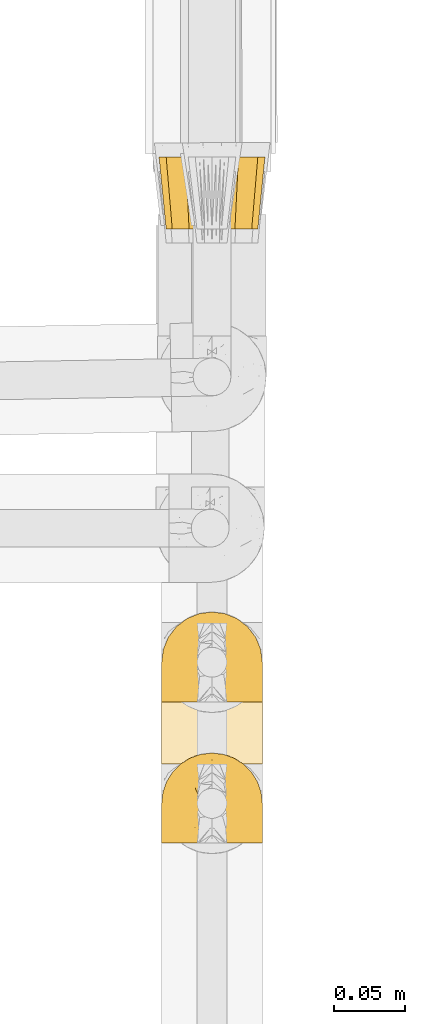
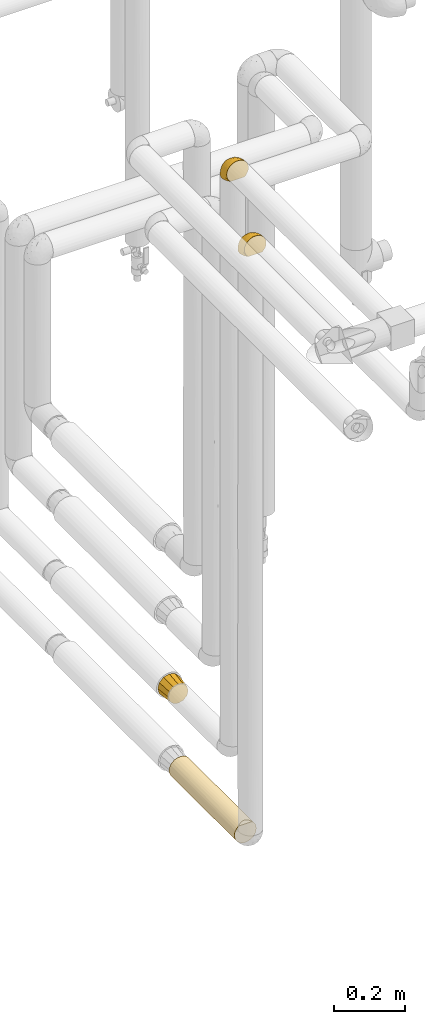
# One storey, part 74 of 827: 4 coverings.
"""IFC2X3 building model written with IfcOpenShell, lengths in millimetres."""

import ifcopenshell
import ifcopenshell.guid

model = None  # the IFC model being written
_history = None  # IfcOwnerHistory: only IFC2X3 demands one
_inside = {}  # id of a spatial element -> (the spatial element, [elements in it])
_under = {}  # id of a project, library or spatial element -> (it, [spatial elements below it])
_declared = {}  # id of a project -> (the project, [libraries it declares])
_typed = {}  # id of a type object -> (the type object, [elements of that type])
_made_of = {}  # id of a material, layer set ... -> (it, [elements and type objects made of it])


def new_model(schema):
    """Start an empty IFC model of exactly this schema.

    Asked for "IFC4X3", IfcOpenShell would pick the latest addendum, in which some entities
    have other attributes; the version numbers below select the first issue.
    IFC2X3 requires an IfcOwnerHistory on every rooted entity: one is made here for all.
    """
    global model, _history
    if schema == "IFC4X3":
        model = ifcopenshell.file(schema_version=(4, 3, 0, 0))
    else:
        model = ifcopenshell.file(schema=schema)
    _inside.clear()
    _under.clear()
    _declared.clear()
    _typed.clear()
    _made_of.clear()
    _history = None
    if model.schema == "IFC2X3":
        org = make("IfcOrganization", Name="unknown")
        user = make(
            "IfcPersonAndOrganization",
            ThePerson=make("IfcPerson", FamilyName="unknown"),
            TheOrganization=org,
        )
        app = make(
            "IfcApplication",
            ApplicationDeveloper=org,
            Version="unknown",
            ApplicationFullName="unknown",
            ApplicationIdentifier="unknown",
        )
        _history = make(
            "IfcOwnerHistory",
            OwningUser=user,
            OwningApplication=app,
            ChangeAction="ADDED",
            CreationDate=0,
        )
    return model


def make(cls, **values):
    """One entity of the class cls with the attributes given. An attribute that is None is left unset."""
    return model.create_entity(
        cls, **{name: value for name, value in values.items() if value is not None}
    )


def entity(cls, *values):
    """Any entity or typed value of the class cls, its attributes in the order of the schema. None: left unset."""
    e = model.create_entity(cls)
    for i, value in enumerate(values):
        if value is not None:
            e[i] = value
    return e


def rooted(cls, **values):
    """An entity with a GlobalId (a new one), such as an element, a storey or a relation."""
    return make(cls, GlobalId=ifcopenshell.guid.new(), OwnerHistory=_history, **values)


def si_unit(unit_type, name, prefix=None):
    """IfcSIUnit, for example si_unit("LENGTHUNIT", "METRE", prefix="MILLI")."""
    return make("IfcSIUnit", UnitType=unit_type, Prefix=prefix, Name=name)


def converted_unit(unit_type, name, factor, base, dimensions=None, offset=None):
    """IfcConversionBasedUnit, such as the inch: factor (a typed value) times the base unit."""
    return make(
        "IfcConversionBasedUnit"
        if offset is None
        else "IfcConversionBasedUnitWithOffset",
        ConversionOffset=offset,
        Dimensions=None
        if dimensions is None
        else entity("IfcDimensionalExponents", *dimensions),
        UnitType=unit_type,
        Name=name,
        ConversionFactor=make(
            "IfcMeasureWithUnit", ValueComponent=factor, UnitComponent=base
        ),
    )


def derived_unit(unit_type, elements):
    """IfcDerivedUnit: a product of units, each with its exponent."""
    return make(
        "IfcDerivedUnit",
        Elements=[
            make("IfcDerivedUnitElement", Unit=unit, Exponent=power)
            for unit, power in elements
        ],
        UnitType=unit_type,
    )


def assignment(units):
    """IfcUnitAssignment: the units of a project."""
    return None if units is None else make("IfcUnitAssignment", Units=units)


def point(xyz):
    """IfcCartesianPoint."""
    return None if xyz is None else make("IfcCartesianPoint", Coordinates=xyz)


def direction(xyz):
    """IfcDirection."""
    return None if xyz is None else make("IfcDirection", DirectionRatios=xyz)


def frame(location, z_axis=None, x_axis=None):
    """IfcAxis2Placement3D, a coordinate frame: its origin and axes. An axis left out is left unset."""
    return make(
        "IfcAxis2Placement3D",
        Location=point(location),
        Axis=direction(z_axis),
        RefDirection=direction(x_axis),
    )


def origin():
    """The frame at (0, 0, 0) with its axes left unset."""
    return frame((0.0, 0.0, 0.0))


def place(relative_to, where):
    """IfcLocalPlacement: puts the frame where relative to a parent placement (None: the world)."""
    return make(
        "IfcLocalPlacement", PlacementRelTo=relative_to, RelativePlacement=where
    )


def context(
    kind, dimensions, precision=None, world=None, true_north=None, identifier=None
):
    """IfcGeometricRepresentationContext, for example the 3D "Model" context."""
    return make(
        "IfcGeometricRepresentationContext",
        ContextIdentifier=identifier,
        ContextType=kind,
        CoordinateSpaceDimension=dimensions,
        Precision=precision,
        WorldCoordinateSystem=world,
        TrueNorth=true_north,
    )


def subcontext(parent, identifier, kind, view, scale=None):
    """IfcGeometricRepresentationSubContext, for example "Body" below "Model"."""
    return make(
        "IfcGeometricRepresentationSubContext",
        ContextIdentifier=identifier,
        ContextType=kind,
        ParentContext=parent,
        TargetScale=scale,
        TargetView=view,
    )


def project(units=None, contexts=None):
    """IfcProject with its units and contexts."""
    return rooted(
        "IfcProject",
        Name="project",
        RepresentationContexts=contexts,
        UnitsInContext=assignment(units),
    )


def spatial(cls, under=None, at=None, **own):
    """A site, building, storey or space (cls), placed at a placement, below another one or the project."""
    s = rooted(cls, ObjectPlacement=at, **own)
    if under is not None:
        _under.setdefault(under.id(), (under, []))[1].append(s)
    return s


def faces_of(points, faces, orient=None, outer=None):
    """IfcFace entities. A face is a list of loops; a loop is a list of indices into points, from 0.

    orient and outer hold one flag for each loop. By default every Orientation is true, the
    first loop of a face is its IfcFaceOuterBound and the others are IfcFaceBound.
    """
    made = []
    for i, loops in enumerate(faces):
        bounds = []
        for j, loop in enumerate(loops):
            is_outer = j == 0 if outer is None else outer[i][j]
            bounds.append(
                make(
                    "IfcFaceOuterBound" if is_outer else "IfcFaceBound",
                    Bound=make("IfcPolyLoop", Polygon=[points[k] for k in loop]),
                    Orientation=True if orient is None else orient[i][j],
                )
            )
        made.append(make("IfcFace", Bounds=bounds))
    return made


def faceted_brep(points, faces, orient=None, outer=None, voids=None):
    """IfcFacetedBrep: a solid bounded by flat faces; with voids (closed shells), ...WithVoids."""
    shared = [point(p) for p in points]
    hull = make("IfcClosedShell", CfsFaces=faces_of(shared, faces, orient, outer))
    if voids is None:
        return make("IfcFacetedBrep", Outer=hull)
    return make(
        "IfcFacetedBrepWithVoids",
        Outer=hull,
        Voids=[
            make(cls, CfsFaces=faces_of(shared, fs, o, b)) for cls, fs, o, b in voids
        ],
    )


def shape(context_of_items, identifier, shape_type, items):
    """IfcShapeRepresentation: the items that make up one representation, for example the "Body"."""
    return make(
        "IfcShapeRepresentation",
        ContextOfItems=context_of_items,
        RepresentationIdentifier=identifier,
        RepresentationType=shape_type,
        Items=items,
    )


def made_of(thing, what):
    """Note that an element or type object is made of a material, layer set ...; save() writes the relation."""
    if what is not None:
        _made_of.setdefault(what.id(), (what, []))[1].append(thing)
    return thing


def element(
    cls,
    number,
    at=None,
    inside=None,
    cuts=None,
    type_object=None,
    material=None,
    context=None,
    identifier="Body",
    shape_type=None,
    held_by="IfcProductDefinitionShape",
    body=None,
    shapes=None,
    **own,
):
    """One element of the class cls, such as IfcWall. Its Tag is "e" and its number.

    at: its placement. inside: the storey or other place that contains it. cuts: it is an
    opening in that element (IfcRelVoidsElement). A single representation is given by context,
    identifier, shape_type and body (its items); several are given by shapes. held_by: the class
    of the entity that holds the representations. save() writes the other relations.
    """
    e = rooted(cls, Tag="e%d" % number, ObjectPlacement=at, **own)
    if body is not None:
        shapes = [shape(context, identifier, shape_type, body)]
    if shapes is not None:
        e.Representation = make(held_by, Representations=shapes)
    if inside is not None:
        _inside.setdefault(inside.id(), (inside, []))[1].append(e)
    if cuts is not None:
        rooted(
            "IfcRelVoidsElement", RelatingBuildingElement=cuts, RelatedOpeningElement=e
        )
    if type_object is not None:
        _typed.setdefault(type_object.id(), (type_object, []))[1].append(e)
    return made_of(e, material)


def aggregate(whole, parts):
    """IfcRelAggregates: a whole, such as a stair, and the parts it consists of."""
    return rooted("IfcRelAggregates", RelatingObject=whole, RelatedObjects=parts)


def save(model, path):
    """Write the relations noted so far, then the file.

    IfcRelAggregates (storeys below a building ...), IfcRelContainedInSpatialStructure (elements
    in a storey), IfcRelDefinesByType, IfcRelAssociatesMaterial and IfcRelDeclares: one each for
    every whole, place, type object, material and project.
    """
    for whole, parts in _under.values():
        aggregate(whole, parts)
    for where, things in _inside.values():
        rooted(
            "IfcRelContainedInSpatialStructure",
            RelatedElements=things,
            RelatingStructure=where,
        )
    for kind, things in _typed.values():
        rooted("IfcRelDefinesByType", RelatedObjects=things, RelatingType=kind)
    for what, things in _made_of.values():
        rooted("IfcRelAssociatesMaterial", RelatedObjects=things, RelatingMaterial=what)
    for by, libraries in _declared.values():
        rooted("IfcRelDeclares", RelatingContext=by, RelatedDefinitions=libraries)
    model.write(path)


model = new_model("IFC2X3")

# Units and contexts
model_context = context("Model", 3, precision=0.01, world=origin(), true_north=direction((6.12303176911189e-17, 1.0)))
body_context = subcontext(model_context, "Body", "Model", "MODEL_VIEW")
ifc_project = project(units=[si_unit("LENGTHUNIT", "METRE", prefix="MILLI"), si_unit("AREAUNIT", "SQUARE_METRE"), si_unit("VOLUMEUNIT", "CUBIC_METRE"), converted_unit("PLANEANGLEUNIT", "DEGREE", entity("IfcRatioMeasure", 0.0174532925199433), si_unit("PLANEANGLEUNIT", "RADIAN"), dimensions=[0, 0, 0, 0, 0, 0, 0]), si_unit("MASSUNIT", "GRAM", prefix="KILO"), derived_unit("MASSDENSITYUNIT", [(si_unit("MASSUNIT", "GRAM", prefix="KILO"), 1), (si_unit("LENGTHUNIT", "METRE"), -3)]), derived_unit("MOMENTOFINERTIAUNIT", [(si_unit("LENGTHUNIT", "METRE"), 4)]), si_unit("TIMEUNIT", "SECOND"), si_unit("FREQUENCYUNIT", "HERTZ"), si_unit("THERMODYNAMICTEMPERATUREUNIT", "DEGREE_CELSIUS"), derived_unit("THERMALTRANSMITTANCEUNIT", [(si_unit("MASSUNIT", "GRAM", prefix="KILO"), 1), (si_unit("THERMODYNAMICTEMPERATUREUNIT", "KELVIN"), -1), (si_unit("TIMEUNIT", "SECOND"), -3)]), derived_unit("VOLUMETRICFLOWRATEUNIT", [(si_unit("LENGTHUNIT", "METRE"), 3), (si_unit("TIMEUNIT", "SECOND"), -1)]), derived_unit("MASSFLOWRATEUNIT", [(si_unit("MASSUNIT", "GRAM", prefix="KILO"), 1), (si_unit("TIMEUNIT", "SECOND"), -1)]), derived_unit("ROTATIONALFREQUENCYUNIT", [(si_unit("TIMEUNIT", "SECOND"), -1)]), si_unit("ELECTRICCURRENTUNIT", "AMPERE"), si_unit("ELECTRICVOLTAGEUNIT", "VOLT"), si_unit("POWERUNIT", "WATT"), si_unit("FORCEUNIT", "NEWTON", prefix="KILO"), si_unit("ILLUMINANCEUNIT", "LUX"), si_unit("LUMINOUSFLUXUNIT", "LUMEN"), si_unit("LUMINOUSINTENSITYUNIT", "CANDELA"), derived_unit("USERDEFINED", [(si_unit("MASSUNIT", "GRAM", prefix="KILO"), -1), (si_unit("LENGTHUNIT", "METRE"), -2), (si_unit("TIMEUNIT", "SECOND"), 3), (si_unit("LUMINOUSFLUXUNIT", "LUMEN"), 1)]), derived_unit("LINEARVELOCITYUNIT", [(si_unit("LENGTHUNIT", "METRE"), 1), (si_unit("TIMEUNIT", "SECOND"), -1)]), si_unit("PRESSUREUNIT", "PASCAL"), derived_unit("USERDEFINED", [(si_unit("LENGTHUNIT", "METRE"), -2), (si_unit("MASSUNIT", "GRAM", prefix="KILO"), 1), (si_unit("TIMEUNIT", "SECOND"), -2)]), derived_unit("LINEARFORCEUNIT", [(si_unit("MASSUNIT", "GRAM", prefix="KILO"), 1), (si_unit("LENGTHUNIT", "METRE"), 1), (si_unit("TIMEUNIT", "SECOND"), -2), (si_unit("LENGTHUNIT", "METRE"), -1)]), derived_unit("PLANARFORCEUNIT", [(si_unit("MASSUNIT", "GRAM", prefix="KILO"), 1), (si_unit("LENGTHUNIT", "METRE"), 1), (si_unit("TIMEUNIT", "SECOND"), -2), (si_unit("LENGTHUNIT", "METRE"), -2)])], contexts=[model_context])

# Site, building, storey
site_placement = place(None, origin())
site = spatial("IfcSite", under=ifc_project, at=site_placement, CompositionType="ELEMENT")
building_placement = place(site_placement, origin())
building = spatial("IfcBuilding", under=site, at=building_placement, CompositionType="ELEMENT")
storey_placement = place(building_placement, frame((0.0, 0.0, 28200.0)))
storey = spatial("IfcBuildingStorey", under=building, at=storey_placement, Name="08", CompositionType="ELEMENT", Elevation=28200.0)

# Coverings
covering_1_placement = place(storey_placement, frame((17891.28, 10631.6, 2820.54)))
element("IfcCovering", 1, at=covering_1_placement, inside=storey, Name=":ADSK_", ObjectType=":ADSK_", PredefinedType="INSULATION", context=body_context, shape_type="Brep", body=[
    faceted_brep([(69.36, 1.6, 45.07), (65.11, 1.6, 51.83), (59.47, 1.6, 57.47), (52.71, 1.6, 61.72), (45.17, 1.6, 64.35), (37.25, 1.6, 65.25), (29.31, 1.6, 64.35), (21.77, 1.6, 61.71), (15.01, 1.6, 57.46), (9.37, 1.6, 51.82), (5.12, 1.6, 45.06), (2.49, 1.6, 37.52), (1.6, 1.6, 29.6), (2.48, 1.6, 21.69), (5.1, 1.6, 14.19), (9.31, 1.6, 7.45), (14.9, 1.6, 1.82), (16.96, 1.6, 1.82), (18.43, 1.6, 1.82), (20.19, 1.6, 1.82), (21.96, 1.6, 1.82), (23.72, 1.6, 1.82), (25.49, 1.6, 1.82), (27.25, 1.6, 1.82), (29.02, 1.6, 1.82), (30.78, 1.6, 1.82), (32.55, 1.6, 1.82), (34.31, 1.6, 1.82), (36.08, 1.6, 1.82), (37.84, 1.6, 1.82), (39.61, 1.6, 1.82), (41.37, 1.6, 1.82), (43.14, 1.6, 1.82), (45.19, 1.6, 1.82), (47.25, 1.6, 1.82), (49.31, 1.6, 1.82), (51.36, 1.6, 1.82), (53.42, 1.6, 1.82), (55.48, 1.6, 1.82), (57.53, 1.6, 1.82), (59.59, 1.6, 1.82), (65.19, 1.6, 7.46), (69.4, 1.6, 14.2), (72.01, 1.6, 21.71), (72.9, 1.6, 29.6), (72.0, 1.6, 37.53), (14.9, 1.82, 1.6), (9.3, 7.46, 1.6), (5.09, 14.2, 1.6), (2.48, 21.7, 1.6), (1.6, 29.6, 1.6), (2.81, 38.83, 1.6), (6.37, 47.43, 1.6), (12.04, 54.81, 1.6), (19.42, 60.47, 1.6), (28.02, 64.04, 1.6), (37.25, 65.25, 1.6), (46.47, 64.04, 1.6), (55.07, 60.47, 1.6), (62.45, 54.81, 1.6), (68.12, 47.43, 1.6), (71.68, 38.83, 1.6), (72.9, 29.6, 1.6), (72.01, 21.7, 1.6), (69.4, 14.2, 1.6), (65.19, 7.46, 1.6), (59.59, 1.82, 1.6), (58.56, 1.82, 1.6), (56.8, 1.82, 1.6), (55.4, 1.82, 1.6), (54.0, 1.82, 1.6), (52.61, 1.82, 1.6), (51.21, 1.82, 1.6), (49.81, 1.82, 1.6), (48.42, 1.82, 1.6), (47.02, 1.82, 1.6), (45.62, 1.82, 1.6), (44.23, 1.82, 1.6), (42.83, 1.82, 1.6), (41.43, 1.82, 1.6), (40.04, 1.82, 1.6), (38.64, 1.82, 1.6), (37.25, 1.82, 1.6), (35.48, 1.82, 1.6), (33.72, 1.82, 1.6), (31.95, 1.82, 1.6), (30.19, 1.82, 1.6), (28.42, 1.82, 1.6), (26.66, 1.82, 1.6), (24.89, 1.82, 1.6), (23.13, 1.82, 1.6), (21.07, 1.82, 1.6), (19.01, 1.82, 1.6), (16.96, 1.82, 1.6), (50.36, 1.75, 1.76), (51.91, 1.76, 1.75), (27.73, 1.76, 1.75), (29.06, 1.77, 1.74), (23.01, 1.75, 1.76), (39.29, 1.76, 1.75), (16.3, 1.76, 1.75), (17.69, 1.76, 1.75), (42.09, 1.76, 1.75), (43.53, 1.76, 1.75), (58.23, 1.75, 1.76), (59.59, 1.76, 1.75), (46.32, 1.75, 1.76), (47.68, 1.76, 1.75), (19.0, 1.75, 1.76), (30.39, 1.76, 1.75), (31.67, 1.74, 1.77), (37.94, 1.77, 1.74), (36.57, 1.76, 1.75), (45.01, 1.76, 1.75), (35.19, 1.74, 1.77), (26.37, 1.74, 1.77), (25.1, 1.76, 1.75), (56.91, 1.75, 1.76), (40.68, 1.76, 1.75), (32.77, 1.79, 1.71), (20.34, 1.77, 1.74), (21.67, 1.76, 1.75), (33.92, 1.76, 1.75), (53.39, 1.77, 1.74), (54.7, 1.76, 1.75), (14.9, 1.76, 1.75), (49.03, 1.76, 1.75), (3.58, 13.11, 13.1), (6.24, 8.19, 9.65), (1.6, 25.85, 15.6), (1.6, 27.73, 8.6), (1.6, 15.6, 25.84), (9.92, 5.21, 5.2), (1.6, 20.72, 20.72), (1.6, 7.07, 28.13), (27.59, 35.56, 53.85), (25.47, 16.98, 61.29), (37.25, 25.95, 60.4), (2.39, 35.65, 11.52), (4.31, 42.61, 8.83), (4.31, 40.07, 17.53), (7.06, 20.45, 44.61), (7.06, 10.53, 47.7), (12.03, 14.87, 53.12), (18.65, 42.8, 43.01), (15.3, 33.34, 47.84), (21.13, 34.61, 51.46), (30.63, 61.84, 20.14), (23.6, 60.44, 17.45), (37.25, 14.29, 62.72), (15.54, 57.01, 11.49), (8.96, 49.61, 14.46), (2.3, 24.93, 27.74), (2.37, 32.74, 18.37), (3.14, 21.53, 34.41), (3.59, 11.52, 40.11), (18.27, 12.66, 58.72), (7.07, 34.11, 35.51), (8.53, 43.52, 27.21), (3.86, 32.29, 28.03), (13.04, 24.41, 50.73), (18.27, 24.95, 54.89), (26.27, 44.19, 46.54), (23.06, 56.25, 28.04), (29.25, 56.83, 31.36), (15.54, 53.51, 23.34), (24.41, 50.94, 37.9), (31.04, 50.38, 41.63), (37.25, 46.61, 46.6), (37.25, 36.28, 53.5), (37.25, 62.73, 14.29), (15.08, 47.4, 33.68), (12.03, 38.92, 39.51), (9.82, 29.55, 43.99), (6.14, 26.82, 39.36), (37.25, 60.41, 25.95), (37.25, 53.51, 36.28), (70.63, 32.3, 28.03), (67.42, 34.1, 35.52), (68.34, 26.82, 39.39), (43.86, 61.84, 20.14), (51.43, 56.24, 28.04), (50.89, 60.44, 17.45), (58.95, 53.51, 23.35), (58.95, 57.01, 11.5), (65.53, 49.61, 14.46), (43.44, 50.38, 41.63), (48.21, 44.18, 46.55), (50.07, 50.94, 37.92), (67.43, 20.45, 44.62), (67.43, 10.52, 47.71), (70.89, 11.52, 40.12), (55.83, 42.79, 43.03), (59.41, 47.39, 33.7), (72.9, 27.73, 8.6), (72.11, 35.65, 11.52), (72.12, 32.74, 18.37), (72.9, 7.07, 28.13), (70.18, 40.07, 17.53), (70.18, 42.61, 8.83), (46.9, 35.54, 53.86), (49.01, 16.98, 61.3), (56.21, 24.95, 54.9), (56.21, 12.65, 58.72), (62.45, 14.87, 53.13), (72.9, 25.85, 15.6), (62.45, 38.91, 39.53), (59.18, 33.34, 47.86), (64.66, 29.54, 44.01), (71.35, 21.54, 34.41), (72.9, 15.6, 25.84), (65.96, 43.51, 27.23), (61.44, 24.4, 50.74), (45.24, 56.83, 31.37), (72.19, 24.93, 27.74), (72.9, 20.72, 20.72), (53.31, 35.61, 50.81), (70.91, 13.11, 13.1), (68.25, 9.66, 8.18), (64.57, 5.21, 5.2)], [[[0, 1, 2, 3, 4, 5, 6, 7, 8, 9, 10, 11, 12, 13, 14, 15, 16, 17, 18, 19, 20, 21, 22, 23, 24, 25, 26, 27, 28, 29, 30, 31, 32, 33, 34, 35, 36, 37, 38, 39, 40, 41, 42, 43, 44, 45]], [[46, 47, 48, 49, 50, 51, 52, 53, 54, 55, 56, 57, 58, 59, 60, 61, 62, 63, 64, 65, 66, 67, 68, 69, 70, 71, 72, 73, 74, 75, 76, 77, 78, 79, 80, 81, 82, 83, 84, 85, 86, 87, 88, 89, 90, 91, 92, 93]], [[94, 72, 95]], [[96, 87, 97]], [[20, 98, 21]], [[99, 81, 80]], [[100, 93, 101]], [[102, 103, 32]], [[104, 105, 40]], [[67, 105, 104]], [[106, 107, 34]], [[18, 101, 108]], [[109, 85, 110]], [[36, 94, 95]], [[81, 111, 82]], [[29, 28, 112]], [[17, 101, 18]], [[103, 113, 33]], [[24, 96, 97]], [[28, 114, 112]], [[115, 22, 116]], [[31, 102, 32]], [[68, 104, 117]], [[31, 118, 102]], [[84, 119, 85]], [[120, 91, 121]], [[23, 22, 115]], [[114, 27, 122]], [[123, 37, 95]], [[117, 124, 69]], [[67, 66, 105]], [[104, 39, 117]], [[123, 124, 37]], [[100, 17, 16]], [[100, 125, 46]], [[17, 100, 101]], [[107, 126, 35]], [[92, 108, 101]], [[115, 88, 96]], [[114, 122, 83]], [[101, 93, 92]], [[93, 100, 46]], [[16, 125, 100]], [[108, 19, 18]], [[120, 121, 19]], [[108, 92, 120]], [[19, 108, 120]], [[67, 104, 68]], [[39, 104, 40]], [[69, 68, 117]], [[117, 39, 38]], [[70, 124, 123]], [[124, 70, 69]], [[38, 124, 117]], [[124, 38, 37]], [[72, 71, 95]], [[71, 123, 95]], [[71, 70, 123]], [[126, 94, 35]], [[37, 36, 95]], [[75, 74, 107]], [[73, 72, 94]], [[94, 36, 35]], [[94, 126, 73]], [[74, 73, 126]], [[106, 76, 75]], [[76, 106, 113]], [[113, 106, 33]], [[107, 35, 34]], [[106, 34, 33]], [[126, 107, 74]], [[107, 106, 75]], [[78, 77, 103]], [[77, 113, 103]], [[77, 76, 113]], [[102, 78, 103]], [[33, 32, 103]], [[80, 79, 118]], [[102, 118, 79]], [[112, 111, 29]], [[118, 31, 30]], [[79, 78, 102]], [[99, 111, 81]], [[112, 82, 111]], [[111, 99, 29]], [[30, 29, 99]], [[112, 83, 82]], [[27, 114, 28]], [[99, 118, 30]], [[118, 99, 80]], [[114, 83, 112]], [[84, 83, 122]], [[109, 110, 25]], [[122, 27, 26]], [[119, 110, 85]], [[20, 19, 121]], [[25, 110, 26]], [[91, 120, 92]], [[90, 98, 121]], [[121, 91, 90]], [[23, 115, 96]], [[88, 115, 116]], [[116, 98, 89]], [[89, 88, 116]], [[23, 96, 24]], [[87, 96, 88]], [[25, 24, 109]], [[97, 87, 86]], [[90, 89, 98]], [[116, 22, 21]], [[122, 26, 119]], [[86, 85, 109]], [[109, 97, 86]], [[97, 109, 24]], [[110, 119, 26]], [[122, 119, 84]], [[121, 98, 20]], [[21, 98, 116]], [[48, 127, 49]], [[48, 47, 128]], [[49, 129, 130, 50]], [[129, 49, 127]], [[131, 127, 13]], [[46, 125, 132]], [[16, 15, 132]], [[127, 128, 14]], [[127, 131, 133, 129]], [[14, 13, 127]], [[13, 12, 134, 131]], [[46, 132, 47]], [[48, 128, 127]], [[47, 132, 128]], [[15, 128, 132]], [[125, 16, 132]], [[15, 14, 128]], [[135, 136, 137]], [[50, 130, 138]], [[139, 52, 51]], [[138, 140, 139]], [[141, 142, 143]], [[144, 145, 146]], [[134, 12, 11]], [[136, 135, 146]], [[147, 55, 148]], [[136, 6, 149]], [[150, 54, 53]], [[151, 53, 52]], [[54, 148, 55]], [[54, 150, 148]], [[151, 52, 139]], [[133, 152, 153]], [[154, 131, 155]], [[134, 11, 155]], [[8, 7, 156]], [[143, 9, 8]], [[155, 131, 134]], [[155, 11, 10]], [[142, 155, 10]], [[157, 158, 159]], [[155, 141, 154]], [[160, 161, 145]], [[160, 143, 161]], [[144, 146, 162]], [[147, 163, 164]], [[136, 7, 6]], [[137, 136, 149]], [[161, 156, 136]], [[165, 151, 158]], [[156, 143, 8]], [[166, 167, 164]], [[9, 142, 10]], [[158, 151, 140]], [[168, 135, 137, 169]], [[130, 153, 138]], [[150, 151, 165]], [[163, 166, 164]], [[55, 147, 170]], [[144, 171, 172]], [[153, 152, 159]], [[141, 173, 174]], [[154, 159, 152]], [[6, 5, 149]], [[136, 156, 7]], [[143, 156, 161]], [[143, 142, 9]], [[155, 142, 141]], [[159, 158, 140]], [[158, 172, 171]], [[153, 140, 138]], [[173, 157, 174]], [[170, 147, 175]], [[170, 56, 55]], [[167, 168, 176]], [[176, 175, 164]], [[147, 164, 175]], [[162, 167, 166]], [[176, 164, 167]], [[163, 147, 148]], [[148, 165, 163]], [[171, 163, 165]], [[144, 162, 166]], [[162, 135, 168]], [[166, 163, 171]], [[145, 144, 172]], [[166, 171, 144]], [[158, 171, 165]], [[173, 145, 172]], [[146, 145, 161]], [[157, 173, 172]], [[160, 141, 143]], [[158, 157, 172]], [[174, 159, 154]], [[136, 146, 161]], [[146, 135, 162]], [[145, 173, 160]], [[141, 160, 173]], [[159, 174, 157]], [[154, 152, 131]], [[154, 141, 174]], [[151, 150, 53]], [[148, 150, 165]], [[51, 50, 138]], [[151, 139, 140]], [[51, 138, 139]], [[153, 130, 129]], [[133, 153, 129]], [[159, 140, 153]], [[168, 167, 162]], [[131, 152, 133]], [[177, 178, 179]], [[175, 180, 170]], [[180, 181, 182]], [[182, 183, 184]], [[185, 60, 59]], [[186, 187, 188]], [[189, 190, 191]], [[192, 193, 188]], [[194, 195, 196]], [[45, 197, 191]], [[185, 198, 199]], [[45, 44, 197]], [[61, 199, 195]], [[199, 61, 60]], [[0, 45, 191]], [[58, 57, 182]], [[200, 137, 201]], [[184, 185, 59]], [[202, 203, 204]], [[1, 204, 2]], [[58, 184, 59]], [[201, 3, 203]], [[201, 149, 4]], [[1, 0, 190]], [[204, 203, 2]], [[196, 205, 194]], [[206, 207, 208]], [[189, 191, 209]], [[191, 210, 209]], [[3, 201, 4]], [[185, 211, 198]], [[190, 204, 1]], [[200, 201, 202]], [[189, 208, 212]], [[207, 206, 192]], [[3, 2, 203]], [[200, 168, 169, 137]], [[210, 191, 197]], [[61, 195, 62]], [[183, 193, 211]], [[57, 170, 180]], [[180, 213, 181]], [[175, 176, 213]], [[188, 187, 192]], [[214, 210, 215]], [[177, 198, 211]], [[149, 201, 137]], [[149, 5, 4]], [[201, 203, 202]], [[191, 190, 0]], [[204, 190, 189]], [[183, 211, 185]], [[208, 178, 206]], [[178, 211, 206]], [[209, 214, 177]], [[57, 56, 170]], [[186, 213, 176]], [[57, 180, 182]], [[187, 186, 168]], [[168, 186, 176]], [[213, 186, 188]], [[213, 188, 181]], [[213, 180, 175]], [[193, 181, 188]], [[183, 182, 181]], [[210, 214, 209]], [[207, 216, 202]], [[187, 200, 216]], [[193, 192, 206]], [[216, 207, 192]], [[202, 204, 212]], [[212, 207, 202]], [[179, 178, 208]], [[208, 189, 179]], [[211, 178, 177]], [[211, 193, 206]], [[193, 183, 181]], [[187, 216, 192]], [[202, 216, 200]], [[189, 212, 204]], [[208, 207, 212]], [[189, 209, 179]], [[196, 215, 205]], [[177, 179, 209]], [[182, 184, 58]], [[185, 184, 183]], [[185, 199, 60]], [[195, 199, 198]], [[195, 198, 196]], [[195, 194, 62]], [[198, 177, 196]], [[196, 177, 214]], [[168, 200, 187]], [[196, 214, 215]], [[63, 62, 194, 205]], [[64, 63, 217]], [[64, 217, 218]], [[65, 219, 66]], [[217, 205, 215, 210]], [[43, 210, 197, 44]], [[65, 218, 219]], [[42, 217, 43]], [[219, 105, 66]], [[41, 218, 42]], [[40, 105, 219]], [[65, 64, 218]], [[40, 219, 41]], [[217, 63, 205]], [[42, 218, 217]], [[210, 43, 217]], [[218, 41, 219]]]),
])
covering_2_placement = place(storey_placement, frame((17889.43, 10968.2, 806.65)))
element("IfcCovering", 2, at=covering_2_placement, inside=storey, Name=":ADSK_", ObjectType=":ADSK_", PredefinedType="INSULATION", context=body_context, shape_type="Brep", body=[
    faceted_brep([(10.95, 0.0, 55.35), (8.77, 0.0, 47.22), (6.6, 0.0, 39.1), (8.77, 0.0, 30.97), (10.95, 0.0, 22.85), (16.9, 0.0, 16.9), (22.85, 0.0, 10.95), (30.97, 0.0, 8.77), (39.1, 0.0, 6.6), (47.22, 0.0, 8.77), (55.35, 0.0, 10.95), (61.29, 0.0, 16.9), (67.24, 0.0, 22.85), (69.42, 0.0, 30.97), (71.6, 0.0, 39.1), (69.42, 0.0, 47.22), (67.24, 0.0, 55.35), (61.29, 0.0, 61.29), (55.35, 0.0, 67.24), (47.22, 0.0, 69.42), (39.1, 0.0, 71.6), (30.97, 0.0, 69.42), (22.85, 0.0, 67.24), (16.9, 0.0, 61.29), (64.71, 51.0, 64.71), (71.57, 51.0, 57.85), (73.22, 51.0, 51.69), (74.91, 51.0, 45.39), (76.6, 51.0, 39.1), (74.91, 51.0, 32.8), (73.22, 51.0, 26.5), (71.57, 51.0, 20.35), (64.71, 51.0, 13.48), (57.85, 51.0, 6.62), (51.69, 51.0, 4.97), (45.39, 51.0, 3.28), (39.1, 51.0, 1.6), (32.8, 51.0, 3.28), (26.5, 51.0, 4.97), (20.35, 51.0, 6.62), (13.48, 51.0, 13.48), (6.62, 51.0, 20.35), (4.97, 51.0, 26.5), (3.28, 51.0, 32.8), (1.6, 51.0, 39.1), (3.28, 51.0, 45.39), (4.97, 51.0, 51.69), (6.62, 51.0, 57.85), (13.48, 51.0, 64.71), (20.35, 51.0, 71.57), (26.5, 51.0, 73.22), (32.8, 51.0, 74.91), (39.1, 51.0, 76.6), (45.39, 51.0, 74.91), (51.69, 51.0, 73.22), (57.85, 51.0, 71.57)], [[[0, 1, 2, 3, 4, 5, 6, 7, 8, 9, 10, 11, 12, 13, 14, 15, 16, 17, 18, 19, 20, 21, 22, 23]], [[24, 25, 26, 27, 28, 29, 30, 31, 32, 33, 34, 35, 36, 37, 38, 39, 40, 41, 42, 43, 44, 45, 46, 47, 48, 49, 50, 51, 52, 53, 54, 55]], [[6, 39, 38, 37, 36, 8, 7]], [[41, 40, 39, 6, 5, 4]], [[44, 43, 42, 41, 4, 3, 2]], [[12, 31, 30, 29, 28, 14, 13]], [[33, 32, 31, 12, 11, 10]], [[36, 35, 34, 33, 10, 9, 8]], [[18, 55, 54, 53, 52, 20, 19]], [[25, 24, 55, 18, 17, 16]], [[28, 27, 26, 25, 16, 15, 14]], [[0, 47, 46, 45, 44, 2, 1]], [[49, 48, 47, 0, 23, 22]], [[52, 51, 50, 49, 22, 21, 20]]]),
])
covering_3_placement = place(storey_placement, frame((17891.28, 10531.61, 2622.13)))
element("IfcCovering", 3, at=covering_3_placement, inside=storey, Name=":ADSK_", ObjectType=":ADSK_", PredefinedType="INSULATION", context=body_context, shape_type="Brep", body=[
    faceted_brep([(5.13, 45.07, 1.6), (9.38, 51.83, 1.6), (15.02, 57.47, 1.6), (21.78, 61.72, 1.6), (29.32, 64.35, 1.6), (37.25, 65.25, 1.6), (45.18, 64.35, 1.6), (52.72, 61.71, 1.6), (59.48, 57.46, 1.6), (65.12, 51.82, 1.6), (69.37, 45.06, 1.6), (72.0, 37.52, 1.6), (72.9, 29.6, 1.6), (72.01, 21.69, 1.6), (69.39, 14.19, 1.6), (65.18, 7.45, 1.6), (59.59, 1.82, 1.6), (57.53, 1.82, 1.6), (56.06, 1.82, 1.6), (54.3, 1.82, 1.6), (52.53, 1.82, 1.6), (50.77, 1.82, 1.6), (49.0, 1.82, 1.6), (47.24, 1.82, 1.6), (45.47, 1.82, 1.6), (43.71, 1.82, 1.6), (41.94, 1.82, 1.6), (40.18, 1.82, 1.6), (38.41, 1.82, 1.6), (36.65, 1.82, 1.6), (34.88, 1.82, 1.6), (33.12, 1.82, 1.6), (31.35, 1.82, 1.6), (29.3, 1.82, 1.6), (27.24, 1.82, 1.6), (25.18, 1.82, 1.6), (23.13, 1.82, 1.6), (21.07, 1.82, 1.6), (19.01, 1.82, 1.6), (16.96, 1.82, 1.6), (14.9, 1.82, 1.6), (9.3, 7.46, 1.6), (5.09, 14.2, 1.6), (2.48, 21.71, 1.6), (1.6, 29.6, 1.6), (2.49, 37.53, 1.6), (59.59, 1.6, 1.82), (65.19, 1.6, 7.46), (69.4, 1.6, 14.2), (72.01, 1.6, 21.7), (72.9, 1.6, 29.6), (71.68, 1.6, 38.82), (68.12, 1.6, 47.42), (62.45, 1.6, 54.8), (55.07, 1.6, 60.47), (46.47, 1.6, 64.03), (37.25, 1.6, 65.25), (28.02, 1.6, 64.03), (19.42, 1.6, 60.47), (12.04, 1.6, 54.8), (6.37, 1.6, 47.42), (2.81, 1.6, 38.82), (1.6, 1.6, 29.6), (2.48, 1.6, 21.7), (5.09, 1.6, 14.2), (9.3, 1.6, 7.46), (14.9, 1.6, 1.82), (15.93, 1.6, 1.82), (17.69, 1.6, 1.82), (19.09, 1.6, 1.82), (20.49, 1.6, 1.82), (21.88, 1.6, 1.82), (23.28, 1.6, 1.82), (24.68, 1.6, 1.82), (26.07, 1.6, 1.82), (27.47, 1.6, 1.82), (28.87, 1.6, 1.82), (30.26, 1.6, 1.82), (31.66, 1.6, 1.82), (33.06, 1.6, 1.82), (34.45, 1.6, 1.82), (35.85, 1.6, 1.82), (37.25, 1.6, 1.82), (39.01, 1.6, 1.82), (40.77, 1.6, 1.82), (42.54, 1.6, 1.82), (44.3, 1.6, 1.82), (46.07, 1.6, 1.82), (47.83, 1.6, 1.82), (49.6, 1.6, 1.82), (51.36, 1.6, 1.82), (53.42, 1.6, 1.82), (55.48, 1.6, 1.82), (57.53, 1.6, 1.82), (24.13, 1.76, 1.75), (22.58, 1.75, 1.76), (46.76, 1.75, 1.76), (45.43, 1.74, 1.76), (51.49, 1.76, 1.74), (35.2, 1.75, 1.76), (58.19, 1.75, 1.75), (56.8, 1.75, 1.75), (32.4, 1.75, 1.75), (30.96, 1.75, 1.76), (16.26, 1.76, 1.74), (14.9, 1.75, 1.75), (28.17, 1.76, 1.74), (26.81, 1.75, 1.76), (55.49, 1.76, 1.75), (44.1, 1.75, 1.75), (42.83, 1.77, 1.74), (36.55, 1.74, 1.76), (37.92, 1.75, 1.76), (29.48, 1.75, 1.76), (39.3, 1.77, 1.73), (48.12, 1.77, 1.74), (49.39, 1.75, 1.75), (17.58, 1.76, 1.74), (33.81, 1.75, 1.75), (41.72, 1.71, 1.78), (54.15, 1.74, 1.76), (52.82, 1.75, 1.76), (40.57, 1.75, 1.75), (21.1, 1.74, 1.76), (19.79, 1.75, 1.75), (59.59, 1.75, 1.75), (25.46, 1.75, 1.76), (70.91, 13.1, 13.11), (68.25, 9.65, 8.18), (72.9, 15.6, 25.84), (72.9, 7.07, 28.13), (72.9, 25.84, 15.6), (64.57, 5.2, 5.2), (72.9, 20.72, 20.72), (72.9, 28.13, 7.07), (46.9, 53.84, 35.56), (49.02, 61.29, 16.98), (37.25, 60.4, 25.95), (72.16, 11.45, 35.4), (72.12, 18.37, 32.74), (65.96, 27.21, 43.51), (58.95, 23.34, 53.51), (65.53, 14.46, 49.6), (70.18, 17.53, 40.07), (70.18, 8.83, 42.61), (67.43, 44.61, 20.45), (67.43, 47.7, 10.52), (62.46, 53.12, 14.87), (72.19, 27.74, 24.92), (53.36, 51.46, 34.61), (43.86, 20.14, 61.84), (50.89, 17.44, 60.43), (37.25, 62.72, 14.29), (58.95, 11.49, 57.0), (55.84, 43.01, 42.79), (59.19, 47.84, 33.34), (71.35, 34.4, 21.53), (70.9, 40.11, 11.52), (56.22, 58.72, 12.66), (67.42, 35.5, 34.11), (70.63, 28.03, 32.29), (61.45, 50.73, 24.41), (56.22, 54.88, 24.95), (48.22, 46.53, 44.19), (51.43, 28.03, 56.24), (45.24, 31.36, 56.83), (50.08, 37.9, 50.94), (43.45, 41.63, 50.38), (37.25, 46.6, 46.6), (37.25, 53.5, 36.28), (37.25, 14.29, 62.72), (59.41, 33.68, 47.39), (62.46, 39.51, 38.92), (64.67, 43.98, 29.55), (68.35, 39.36, 26.82), (37.25, 25.95, 60.4), (37.25, 36.28, 53.5), (4.31, 12.43, 41.8), (30.45, 20.13, 61.8), (25.32, 40.53, 49.33), (27.59, 53.86, 35.54), (12.04, 53.13, 14.87), (18.28, 58.72, 12.65), (8.96, 20.81, 47.44), (15.54, 15.78, 56.06), (16.32, 31.15, 50.17), (7.06, 44.62, 20.44), (7.06, 47.71, 10.52), (3.6, 40.12, 11.52), (19.36, 47.19, 38.79), (2.28, 14.97, 33.87), (1.6, 15.6, 25.84), (1.6, 8.6, 27.72), (1.6, 28.13, 7.07), (25.07, 12.48, 62.13), (8.96, 10.34, 50.52), (29.08, 31.94, 56.47), (23.6, 23.68, 58.39), (25.48, 61.3, 16.98), (7.69, 31.18, 39.3), (4.1, 19.63, 38.56), (18.28, 54.89, 24.94), (2.18, 20.57, 30.34), (2.39, 26.89, 26.49), (1.6, 25.84, 15.6), (1.6, 20.72, 20.72), (12.04, 48.57, 26.6), (3.15, 34.41, 21.54), (2.24, 8.15, 35.7), (12.04, 39.53, 38.91), (6.5, 37.32, 30.65), (11.64, 31.82, 44.9), (3.92, 26.03, 34.09), (3.58, 13.1, 13.11), (6.24, 8.18, 9.65), (9.92, 5.2, 5.2)], [[[0, 1, 2, 3, 4, 5, 6, 7, 8, 9, 10, 11, 12, 13, 14, 15, 16, 17, 18, 19, 20, 21, 22, 23, 24, 25, 26, 27, 28, 29, 30, 31, 32, 33, 34, 35, 36, 37, 38, 39, 40, 41, 42, 43, 44, 45]], [[46, 47, 48, 49, 50, 51, 52, 53, 54, 55, 56, 57, 58, 59, 60, 61, 62, 63, 64, 65, 66, 67, 68, 69, 70, 71, 72, 73, 74, 75, 76, 77, 78, 79, 80, 81, 82, 83, 84, 85, 86, 87, 88, 89, 90, 91, 92, 93]], [[94, 72, 95]], [[96, 87, 97]], [[20, 98, 21]], [[99, 81, 80]], [[100, 93, 101]], [[102, 103, 32]], [[104, 105, 40]], [[67, 105, 104]], [[106, 107, 34]], [[18, 101, 108]], [[109, 85, 110]], [[36, 94, 95]], [[81, 111, 82]], [[29, 28, 112]], [[17, 101, 18]], [[103, 113, 33]], [[24, 96, 97]], [[28, 114, 112]], [[115, 22, 116]], [[31, 102, 32]], [[68, 104, 117]], [[31, 118, 102]], [[84, 119, 85]], [[120, 91, 121]], [[23, 22, 115]], [[114, 27, 122]], [[123, 37, 95]], [[117, 124, 69]], [[67, 66, 105]], [[104, 39, 117]], [[123, 124, 37]], [[100, 17, 16]], [[100, 125, 46]], [[17, 100, 101]], [[107, 126, 35]], [[92, 108, 101]], [[115, 88, 96]], [[114, 122, 83]], [[101, 93, 92]], [[93, 100, 46]], [[16, 125, 100]], [[108, 19, 18]], [[120, 121, 19]], [[108, 92, 120]], [[19, 108, 120]], [[67, 104, 68]], [[39, 104, 40]], [[69, 68, 117]], [[117, 39, 38]], [[70, 124, 123]], [[124, 70, 69]], [[38, 124, 117]], [[124, 38, 37]], [[72, 71, 95]], [[71, 123, 95]], [[71, 70, 123]], [[126, 94, 35]], [[37, 36, 95]], [[75, 74, 107]], [[73, 72, 94]], [[94, 36, 35]], [[94, 126, 73]], [[74, 73, 126]], [[106, 76, 75]], [[76, 106, 113]], [[113, 106, 33]], [[107, 35, 34]], [[106, 34, 33]], [[126, 107, 74]], [[107, 106, 75]], [[78, 77, 103]], [[77, 113, 103]], [[77, 76, 113]], [[102, 78, 103]], [[33, 32, 103]], [[80, 79, 118]], [[102, 118, 79]], [[112, 111, 29]], [[118, 31, 30]], [[79, 78, 102]], [[99, 111, 81]], [[112, 82, 111]], [[111, 99, 29]], [[30, 29, 99]], [[112, 83, 82]], [[27, 114, 28]], [[99, 118, 30]], [[118, 99, 80]], [[114, 83, 112]], [[84, 83, 122]], [[109, 110, 25]], [[122, 27, 26]], [[119, 110, 85]], [[20, 19, 121]], [[25, 110, 26]], [[91, 120, 92]], [[90, 98, 121]], [[121, 91, 90]], [[23, 115, 96]], [[88, 115, 116]], [[116, 98, 89]], [[89, 88, 116]], [[23, 96, 24]], [[87, 96, 88]], [[25, 24, 109]], [[97, 87, 86]], [[90, 89, 98]], [[116, 22, 21]], [[122, 26, 119]], [[86, 85, 109]], [[109, 97, 86]], [[97, 109, 24]], [[110, 119, 26]], [[122, 119, 84]], [[121, 98, 20]], [[21, 98, 116]], [[48, 127, 49]], [[48, 47, 128]], [[49, 129, 130, 50]], [[129, 49, 127]], [[131, 127, 13]], [[46, 125, 132]], [[16, 15, 132]], [[127, 128, 14]], [[127, 131, 133, 129]], [[14, 13, 127]], [[13, 12, 134, 131]], [[46, 132, 47]], [[48, 128, 127]], [[47, 132, 128]], [[15, 128, 132]], [[125, 16, 132]], [[15, 14, 128]], [[135, 136, 137]], [[138, 129, 139]], [[140, 141, 142]], [[143, 144, 138]], [[145, 146, 147]], [[133, 148, 139]], [[134, 12, 11]], [[136, 135, 149]], [[150, 55, 151]], [[136, 6, 152]], [[153, 54, 53]], [[52, 144, 142]], [[52, 142, 53]], [[54, 153, 151]], [[144, 52, 51]], [[154, 155, 149]], [[156, 131, 157]], [[134, 11, 157]], [[8, 7, 158]], [[147, 9, 8]], [[157, 131, 134]], [[157, 11, 10]], [[146, 157, 10]], [[159, 140, 160]], [[157, 145, 156]], [[161, 162, 155]], [[161, 147, 162]], [[154, 149, 163]], [[150, 164, 165]], [[136, 7, 6]], [[137, 136, 152]], [[162, 158, 136]], [[54, 151, 55]], [[158, 147, 8]], [[166, 167, 165]], [[9, 146, 10]], [[164, 166, 165]], [[168, 135, 137, 169]], [[55, 150, 170]], [[154, 171, 172]], [[139, 148, 160]], [[140, 142, 143]], [[153, 142, 141]], [[51, 50, 130]], [[145, 173, 174]], [[156, 160, 148]], [[6, 5, 152]], [[136, 158, 7]], [[147, 158, 162]], [[147, 146, 9]], [[157, 146, 145]], [[160, 140, 143]], [[140, 172, 171]], [[139, 143, 138]], [[173, 159, 174]], [[170, 150, 175]], [[170, 56, 55]], [[167, 168, 176]], [[176, 175, 165]], [[150, 165, 175]], [[163, 167, 166]], [[176, 165, 167]], [[164, 150, 151]], [[151, 141, 164]], [[171, 164, 141]], [[154, 163, 166]], [[163, 135, 168]], [[166, 164, 171]], [[155, 154, 172]], [[166, 171, 154]], [[140, 171, 141]], [[173, 155, 172]], [[149, 155, 162]], [[159, 173, 172]], [[161, 145, 147]], [[140, 159, 172]], [[174, 160, 156]], [[136, 149, 162]], [[149, 135, 163]], [[155, 173, 161]], [[145, 161, 173]], [[160, 174, 159]], [[156, 148, 131]], [[156, 145, 174]], [[142, 153, 53]], [[151, 153, 141]], [[138, 51, 130]], [[142, 144, 143]], [[51, 138, 144]], [[129, 138, 130]], [[133, 139, 129]], [[160, 143, 139]], [[168, 167, 163]], [[131, 148, 133]], [[60, 177, 61]], [[175, 178, 170]], [[179, 168, 180]], [[178, 57, 170]], [[181, 182, 2]], [[183, 184, 185]], [[186, 187, 188]], [[189, 185, 179]], [[190, 191, 192]], [[45, 193, 188]], [[194, 184, 58]], [[45, 44, 193]], [[59, 195, 60]], [[60, 195, 177]], [[0, 45, 188]], [[196, 179, 197]], [[180, 137, 198]], [[183, 199, 200]], [[201, 182, 181]], [[1, 181, 2]], [[57, 178, 194]], [[198, 3, 182]], [[198, 152, 4]], [[1, 0, 187]], [[190, 202, 191]], [[203, 204, 205]], [[206, 201, 181]], [[186, 188, 207]], [[188, 204, 207]], [[3, 198, 4]], [[58, 184, 59]], [[187, 181, 1]], [[180, 198, 201]], [[206, 181, 186]], [[180, 189, 179]], [[3, 2, 182]], [[180, 168, 169, 137]], [[204, 188, 193]], [[177, 190, 208]], [[209, 210, 199]], [[210, 186, 207]], [[185, 184, 197]], [[195, 184, 183]], [[205, 202, 203]], [[210, 209, 206]], [[179, 185, 197]], [[211, 209, 199]], [[196, 197, 178]], [[180, 201, 189]], [[152, 198, 137]], [[152, 5, 4]], [[61, 208, 62]], [[198, 182, 201]], [[188, 187, 0]], [[181, 187, 186]], [[203, 210, 207]], [[202, 205, 191]], [[199, 210, 212]], [[57, 56, 170]], [[176, 196, 175]], [[178, 197, 194]], [[179, 176, 168]], [[175, 196, 178]], [[176, 179, 196]], [[184, 194, 197]], [[58, 57, 194]], [[208, 190, 192]], [[200, 190, 177]], [[206, 189, 201]], [[185, 189, 209]], [[62, 208, 192]], [[177, 208, 61]], [[210, 206, 186]], [[189, 206, 209]], [[200, 199, 212]], [[211, 183, 185]], [[184, 195, 59]], [[177, 195, 183]], [[183, 200, 177]], [[202, 200, 212]], [[200, 202, 190]], [[202, 212, 203]], [[210, 203, 212]], [[204, 203, 207]], [[183, 211, 199]], [[185, 209, 211]], [[63, 62, 192, 191]], [[64, 63, 213]], [[64, 213, 214]], [[65, 215, 66]], [[213, 191, 205, 204]], [[43, 204, 193, 44]], [[65, 214, 215]], [[42, 213, 43]], [[215, 105, 66]], [[41, 214, 42]], [[40, 105, 215]], [[65, 64, 214]], [[40, 215, 41]], [[213, 63, 191]], [[42, 214, 213]], [[204, 43, 213]], [[214, 41, 215]]]),
])
covering_4_placement = place(storey_placement, frame((17891.28, 10587.61, 562.11)))
element("IfcCovering", 4, at=covering_4_placement, inside=storey, Name=":ADSK_", ObjectType=":ADSK_", PredefinedType="INSULATION", context=body_context, shape_type="Brep", body=[
    faceted_brep([(12.04, 1.6, 12.04), (19.42, 1.6, 6.37), (28.02, 1.6, 2.81), (37.25, 1.6, 1.6), (46.47, 1.6, 2.81), (55.07, 1.6, 6.37), (62.45, 1.6, 12.04), (68.12, 1.6, 19.42), (71.68, 1.6, 28.02), (72.9, 1.6, 37.25), (71.99, 1.6, 45.24), (69.32, 1.6, 52.81), (65.02, 1.6, 59.6), (59.31, 1.6, 65.25), (15.18, 1.6, 65.25), (9.47, 1.6, 59.6), (5.17, 1.6, 52.81), (2.5, 1.6, 45.24), (1.6, 1.6, 37.25), (2.81, 1.6, 28.02), (6.37, 1.6, 19.42), (28.02, 370.6, 2.81), (19.42, 370.6, 6.37), (12.04, 370.6, 12.04), (6.37, 370.6, 19.42), (2.81, 370.6, 28.02), (1.6, 370.6, 37.25), (2.81, 370.6, 46.47), (6.37, 370.6, 55.07), (12.04, 370.6, 62.45), (19.42, 370.6, 68.12), (28.02, 370.6, 71.68), (37.25, 370.6, 72.9), (46.47, 370.6, 71.68), (55.07, 370.6, 68.12), (62.45, 370.6, 62.45), (68.12, 370.6, 55.07), (71.68, 370.6, 46.47), (72.9, 370.6, 37.25), (71.68, 370.6, 28.02), (68.12, 370.6, 19.42), (62.45, 370.6, 12.04), (55.07, 370.6, 6.37), (46.47, 370.6, 2.81), (37.25, 370.6, 1.6), (8.96, 186.1, 15.54), (4.31, 186.1, 23.6), (30.02, 186.1, 2.33), (37.25, 210.08, 1.6), (37.25, 162.11, 1.6), (2.33, 186.1, 30.02), (1.6, 162.11, 37.25), (1.6, 210.08, 37.25), (15.54, 186.1, 8.96), (23.6, 186.1, 4.31), (50.89, 186.1, 4.31), (44.47, 186.1, 2.33), (72.16, 186.1, 30.02), (58.95, 186.1, 8.96), (65.53, 186.1, 15.54), (72.9, 210.08, 37.25), (72.9, 162.11, 37.25), (70.18, 186.1, 23.6), (70.87, 176.38, 49.1), (68.07, 178.19, 55.15), (45.59, 183.62, 71.91), (48.92, 7.28, 70.93), (43.17, 8.75, 72.4), (64.18, 191.44, 60.6), (37.25, 217.73, 72.9), (57.79, 193.79, 66.38), (54.35, 4.87, 68.52), (51.77, 193.87, 69.8), (37.25, 9.25, 72.9), (28.9, 183.62, 71.91), (31.32, 8.75, 72.4), (16.7, 193.79, 66.38), (22.72, 193.87, 69.8), (20.14, 4.87, 68.52), (25.57, 7.28, 70.93), (6.42, 178.19, 55.15), (10.31, 191.44, 60.6), (3.62, 176.38, 49.1)], [[[0, 1, 2, 3, 4, 5, 6, 7, 8, 9, 10, 11, 12, 13, 14, 15, 16, 17, 18, 19, 20]], [[21, 22, 23, 24, 25, 26, 27, 28, 29, 30, 31, 32, 33, 34, 35, 36, 37, 38, 39, 40, 41, 42, 43, 44]], [[45, 46, 24]], [[3, 47, 44, 48, 49]], [[25, 24, 46]], [[50, 25, 46]], [[46, 19, 50]], [[46, 45, 20]], [[23, 45, 24]], [[51, 52, 26, 50, 18]], [[0, 20, 45]], [[26, 25, 50]], [[53, 45, 23]], [[19, 46, 20]], [[54, 22, 21]], [[18, 50, 19]], [[22, 53, 23]], [[3, 2, 47]], [[53, 1, 0]], [[54, 53, 22]], [[47, 2, 54]], [[54, 1, 53]], [[45, 53, 0]], [[1, 54, 2]], [[44, 47, 21]], [[54, 21, 47]], [[55, 56, 43]], [[38, 57, 39]], [[44, 56, 3, 49, 48]], [[55, 43, 42]], [[56, 44, 43]], [[4, 55, 5]], [[55, 4, 56]], [[58, 6, 5]], [[58, 55, 42]], [[59, 58, 41]], [[9, 57, 38, 60, 61]], [[62, 40, 39]], [[57, 8, 62]], [[9, 8, 57]], [[59, 7, 6]], [[62, 59, 40]], [[62, 39, 57]], [[62, 7, 59]], [[58, 59, 6]], [[41, 58, 42]], [[7, 62, 8]], [[40, 59, 41]], [[3, 56, 4]], [[55, 58, 5]], [[63, 60, 37]], [[36, 64, 63]], [[65, 33, 32]], [[66, 65, 67]], [[64, 68, 12]], [[69, 65, 32]], [[37, 60, 38]], [[10, 9, 61, 60]], [[10, 63, 11]], [[64, 11, 63]], [[35, 34, 70]], [[68, 70, 13]], [[71, 72, 66]], [[36, 68, 64]], [[68, 36, 35]], [[73, 67, 69]], [[12, 11, 64]], [[69, 67, 65]], [[68, 13, 12]], [[72, 71, 70]], [[34, 33, 72]], [[65, 72, 33]], [[71, 13, 70]], [[66, 72, 65]], [[36, 63, 37]], [[72, 70, 34]], [[70, 68, 35]], [[60, 63, 10]], [[32, 74, 69]], [[74, 32, 31]], [[69, 74, 75]], [[76, 77, 30]], [[31, 30, 77]], [[30, 29, 76]], [[77, 74, 31]], [[77, 76, 78]], [[77, 78, 79]], [[79, 75, 74]], [[14, 78, 76]], [[75, 73, 69]], [[28, 80, 81]], [[28, 81, 29]], [[28, 27, 82]], [[81, 80, 15]], [[81, 15, 14]], [[17, 52, 51, 18]], [[82, 16, 80]], [[28, 82, 80]], [[52, 82, 27]], [[16, 82, 17]], [[52, 17, 82]], [[26, 52, 27]], [[16, 15, 80]], [[14, 76, 81]], [[79, 74, 77]], [[76, 29, 81]], [[71, 66, 67, 73, 75, 79, 78, 14, 13]]]),
])

save(model, "model.ifc")
